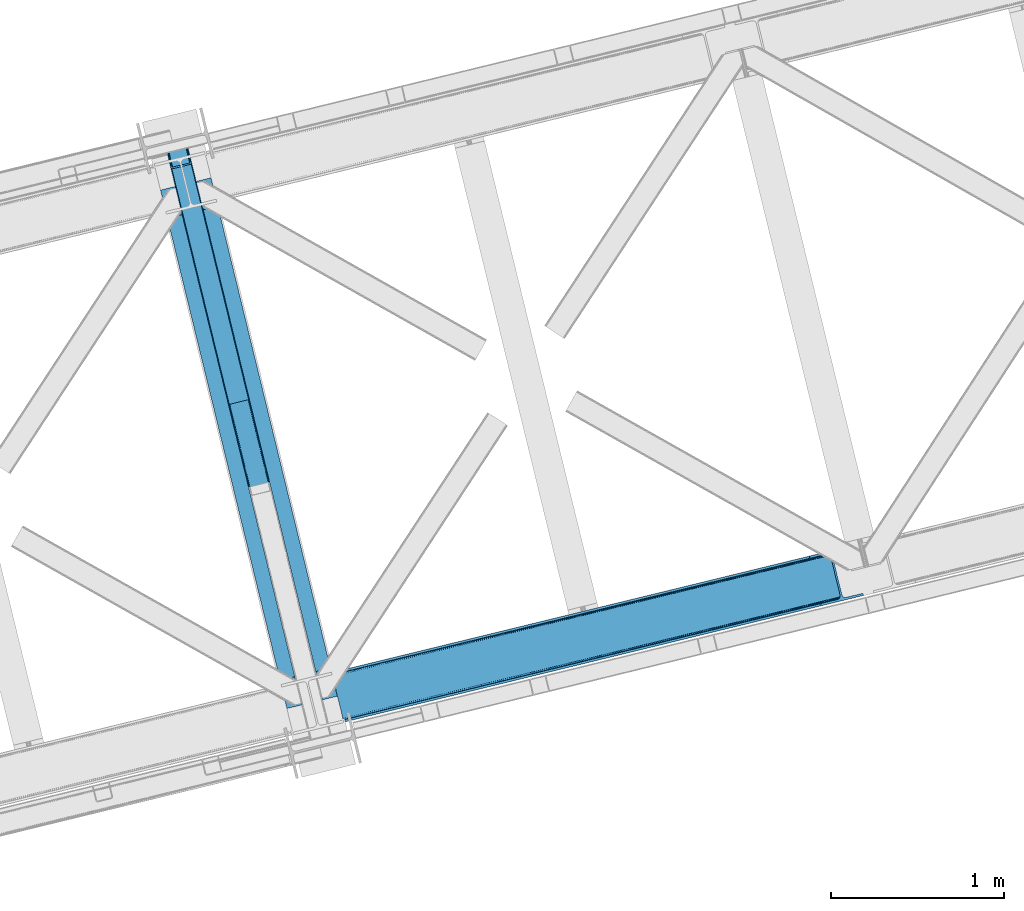
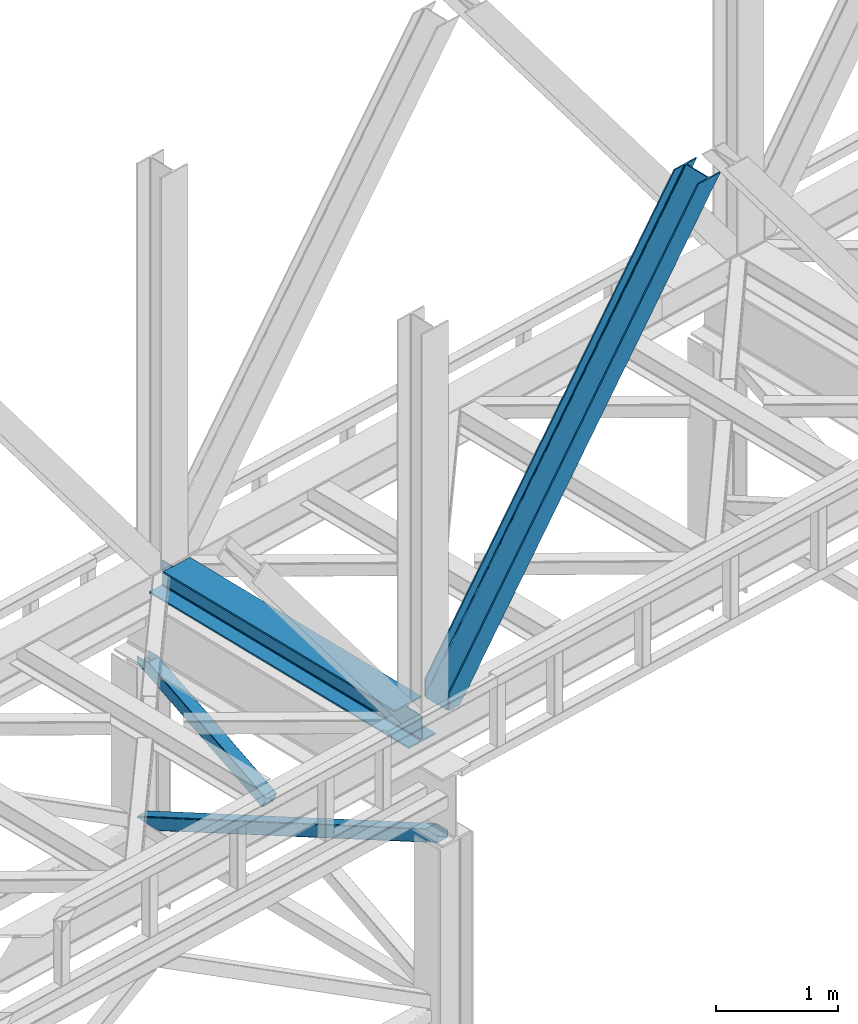
# One storey, part 52 of 92: 3 members, 1 beam.
"""IFC4 building model written with IfcOpenShell, lengths in millimetres."""

from ifc_helpers import new_model, entity, si_unit, converted_unit, derived_unit, direction, frame, origin, place, context, subcontext, project, spatial, triangles, polygons, material, type_object, element, save


model = new_model("IFC4")

# Units and contexts
model_context = context("Model", 3, precision=0.01, world=origin(), true_north=direction((6.12303176911189e-17, 1.0)))
plan_context = context("Plan", 3, precision=0.01, world=origin(), true_north=direction((6.12303176911189e-17, 1.0)))
body_context = subcontext(model_context, "Body", "Model", "MODEL_VIEW")
ifc_project = project(units=[si_unit("LENGTHUNIT", "METRE", prefix="MILLI"), si_unit("AREAUNIT", "SQUARE_METRE"), si_unit("VOLUMEUNIT", "CUBIC_METRE"), converted_unit("PLANEANGLEUNIT", "DEGREE", entity("IfcRatioMeasure", 0.0174532925199433), si_unit("PLANEANGLEUNIT", "RADIAN"), dimensions=[0, 0, 0, 0, 0, 0, 0]), si_unit("MASSUNIT", "GRAM", prefix="KILO"), derived_unit("MASSDENSITYUNIT", [(si_unit("MASSUNIT", "GRAM", prefix="KILO"), 1), (si_unit("LENGTHUNIT", "METRE"), -3)]), derived_unit("MOMENTOFINERTIAUNIT", [(si_unit("LENGTHUNIT", "METRE"), 4)]), si_unit("TIMEUNIT", "SECOND"), si_unit("FREQUENCYUNIT", "HERTZ"), si_unit("THERMODYNAMICTEMPERATUREUNIT", "DEGREE_CELSIUS"), derived_unit("THERMALTRANSMITTANCEUNIT", [(si_unit("MASSUNIT", "GRAM", prefix="KILO"), 1), (si_unit("THERMODYNAMICTEMPERATUREUNIT", "KELVIN"), -1), (si_unit("TIMEUNIT", "SECOND"), -3)]), derived_unit("VOLUMETRICFLOWRATEUNIT", [(si_unit("LENGTHUNIT", "METRE"), 3), (si_unit("TIMEUNIT", "SECOND"), -1)]), derived_unit("MASSFLOWRATEUNIT", [(si_unit("MASSUNIT", "GRAM", prefix="KILO"), 1), (si_unit("TIMEUNIT", "SECOND"), -1)]), derived_unit("ROTATIONALFREQUENCYUNIT", [(si_unit("TIMEUNIT", "SECOND"), -1)]), si_unit("ELECTRICCURRENTUNIT", "AMPERE"), si_unit("ELECTRICVOLTAGEUNIT", "VOLT"), si_unit("POWERUNIT", "WATT"), si_unit("FORCEUNIT", "NEWTON", prefix="KILO"), si_unit("ILLUMINANCEUNIT", "LUX"), si_unit("LUMINOUSFLUXUNIT", "LUMEN"), si_unit("LUMINOUSINTENSITYUNIT", "CANDELA"), derived_unit("USERDEFINED", [(si_unit("MASSUNIT", "GRAM", prefix="KILO"), -1), (si_unit("LENGTHUNIT", "METRE"), -2), (si_unit("TIMEUNIT", "SECOND"), 3), (si_unit("LUMINOUSFLUXUNIT", "LUMEN"), 1)]), derived_unit("LINEARVELOCITYUNIT", [(si_unit("LENGTHUNIT", "METRE"), 1), (si_unit("TIMEUNIT", "SECOND"), -1)]), si_unit("PRESSUREUNIT", "PASCAL"), derived_unit("USERDEFINED", [(si_unit("LENGTHUNIT", "METRE"), -2), (si_unit("MASSUNIT", "GRAM", prefix="KILO"), 1), (si_unit("TIMEUNIT", "SECOND"), -2)]), derived_unit("LINEARFORCEUNIT", [(si_unit("MASSUNIT", "GRAM", prefix="KILO"), 1), (si_unit("LENGTHUNIT", "METRE"), 1), (si_unit("TIMEUNIT", "SECOND"), -2), (si_unit("LENGTHUNIT", "METRE"), -1)]), derived_unit("PLANARFORCEUNIT", [(si_unit("MASSUNIT", "GRAM", prefix="KILO"), 1), (si_unit("LENGTHUNIT", "METRE"), 1), (si_unit("TIMEUNIT", "SECOND"), -2), (si_unit("LENGTHUNIT", "METRE"), -2)])], contexts=[model_context, plan_context])

# Site, building, storey
site_placement = place(None, origin())
site = spatial("IfcSite", under=ifc_project, at=site_placement, CompositionType="ELEMENT")
building_placement = place(site_placement, origin())
building = spatial("IfcBuilding", under=site, at=building_placement, CompositionType="ELEMENT")
storey_placement = place(building_placement, frame((0.0, 0.0, 15900.0)))
storey = spatial("IfcBuildingStorey", under=building, at=storey_placement, Name="05", CompositionType="ELEMENT", Elevation=15900.0)

# Beam
ifc_material = material(Name="Metal painted (White)")
beam_type = type_object("IfcBeamType", PredefinedType="BEAM")
beam_placement = place(storey_placement, frame((-36670.83, 8847.8, 3385.0)))
element("IfcBeam", 1, at=beam_placement, inside=storey, type_object=beam_type, material=ifc_material, ObjectType="Steel Beam", PredefinedType="BEAM", context=body_context, shape_type="Tessellation", body=[
    polygons([(1022.42935345712, 71.0478278971032, 15.4999999999986), (1022.42935345712, 71.047827897101, 0.0), (291.465617442442, 3069.74325535076, 0.0), (291.465617442442, 3069.74325535076, 15.4999999999986), (899.042242073157, 40.970914087328, 15.4999999999986), (168.078506058478, 3039.66634154099, 15.4999999999986), (892.349898299203, 39.3395844888254, 16.8701684147963), (161.386162284524, 3038.03501194248, 16.8701684147963), (886.676403198579, 37.9566100336519, 20.7720779386413), (155.7126671839, 3036.65203748731, 20.7720779386413), (882.88549497, 37.0325360459162, 26.6116982174294), (151.921758955325, 3035.72796349958, 26.6116982174294), (881.554305026607, 36.7080444135029, 33.500000000001), (150.590569011932, 3035.40347186716, 33.500000000001), (140.875048430518, 3033.03521093726, 33.500000000001), (140.875048430518, 3033.03521093726, 259.000000000002), (150.590569011932, 3035.40347186716, 259.000000000002), (4.33146851719357e-12, 2998.69542745366, 0.0), (4.33146851719357e-12, 2998.69542745366, 15.4999999999986), (123.387111383964, 3028.77234126343, 15.4999999999986), (130.079455157922, 3030.40367086194, 16.8701684147963), (135.752950258542, 3031.78664531711, 20.7720779386413), (139.543858487117, 3032.71071930484, 26.6116982174294), (881.554305026612, 36.7080444135018, 259.000000000002), (871.838784445197, 34.3397834835992, 259.000000000002), (871.838784445197, 34.3397834835981, 33.500000000001), (870.507594501796, 34.0152918511827, 26.6116982174294), (866.716686273221, 33.0912178634492, 20.7720779386413), (861.043191172601, 31.7082434082767, 16.8701684147963), (854.350847398639, 30.0769138097708, 15.4999999999986), (730.963736014684, 1.08286712929839e-12, 15.4999999999986), (730.963736014675, 1.08286712929839e-12, 0.0), (841.854534586248, 199.571930111232, 259.069791776412), (190.199733064572, 2872.911390143, 259.000000000002), (190.423126166417, 2871.99494573803, 259.61730333112), (190.435515010051, 2871.94412150426, 266.500003008253), (841.709355772749, 200.167408132524, 266.500002998871), (841.709705893497, 200.16597182779, 260.000004007589), (832.229597305449, 196.831858094286, 259.006343172366), (832.006227290708, 197.748309612731, 259.61730333112), (831.993838447078, 197.799133846506, 266.500003008253), (180.719997684385, 2869.57584721824, 266.500002998871), (180.719647563629, 2869.57728352297, 260.000004007589), (180.574841905293, 2870.17133233676, 259.07612046749), (180.484212483149, 2870.5431292131, 259.000000000002), (843.040843642663, 200.490677577209, 273.388305639783), (846.831120231363, 201.417342749122, 279.227924098781), (852.504191178897, 202.8020572128, 283.129832400619), (859.196382860031, 204.434010743613, 284.500000377228), (982.583411547866, 234.511263798723, 284.500000138971), (982.581741741215, 234.518113867454, 299.999995328161), (691.116319643944, 163.469484603412, 299.999995890962), (691.117989450605, 163.462634534681, 284.500000701776), (814.50501813844, 193.539887589791, 284.500000463519), (821.197505034579, 195.170630056369, 283.129832461069), (826.871416683348, 196.551895700895, 279.227924137322), (830.662951470335, 197.473399350192, 273.388305663684), (179.388509814454, 2869.25257777355, 273.388305639783), (175.598233225758, 2868.32591260164, 279.227924098781), (169.925162278228, 2866.94119813796, 283.129832400619), (163.232970597094, 2865.30924460715, 284.500000377228), (39.8459419092591, 2835.23199155204, 284.500000138971), (39.8476117159108, 2835.22514148331, 299.999995328161), (331.313033813177, 2906.27377074735, 299.999995890962), (331.311364006521, 2906.28062081608, 284.500000701776), (207.924335318677, 2876.20336776097, 284.500000463519), (201.231848422542, 2874.57262529439, 283.129832461069), (195.557936773782, 2873.19135964986, 279.227924137322), (191.766401986782, 2872.26985600057, 273.388305663684)], [[[1, 2, 3, 4]], [[5, 1, 4, 6]], [[7, 5, 6, 8]], [[9, 7, 8, 10]], [[11, 9, 10, 12]], [[13, 11, 12, 14]], [[15, 16, 17, 14, 12, 10, 8, 6, 4, 3, 18, 19, 20, 21, 22, 23]], [[13, 24, 25, 26, 27, 28, 29, 30, 31, 32, 2, 1, 5, 7, 9, 11]], [[2, 32, 18, 3]], [[32, 31, 19, 18]], [[31, 30, 20, 19]], [[27, 26, 15, 23]], [[28, 27, 23, 22]], [[29, 28, 22, 21]], [[30, 29, 21, 20]], [[33, 24, 13, 14, 17, 34, 35, 36, 37, 38]], [[25, 39, 40, 41, 42, 43, 44, 16, 15, 26]], [[39, 25, 24, 33]], [[45, 34, 17, 16]], [[41, 40, 38, 37, 46, 47, 48, 49, 50, 51, 52, 53, 54, 55, 56, 57]], [[42, 58, 59, 60, 61, 62, 63, 64, 65, 66, 67, 68, 69, 36, 35, 43]], [[46, 37, 36, 69]], [[47, 46, 69, 68]], [[48, 47, 68, 67]], [[49, 48, 67, 66]], [[50, 49, 66, 65]], [[51, 50, 65, 64]], [[52, 51, 64, 63]], [[53, 52, 63, 62]], [[54, 53, 62, 61]], [[55, 54, 61, 60]], [[56, 55, 60, 59]], [[57, 56, 59, 58]], [[41, 57, 58, 42]]], closed=False),
])

# Members
member_type_1 = type_object("IfcMemberType", PredefinedType="BRACE")
member_1_placement = place(storey_placement, frame((-35677.02, 8771.36, 3695.0)))
element("IfcMember", 2, at=member_1_placement, inside=storey, type_object=member_type_1, ObjectType="Steel Vertical Brace", PredefinedType="BRACE", context=body_context, shape_type="Tessellation", body=[
    triangles([(58.5289855957017, 27.9221328735348, 0.0), (60.4567749023481, 20.0173828124989, 0.0), (59.0987182617173, 20.9713943481438, 0.827856445310317), (58.9708190917954, 19.7935592651356, 1.13481445312209), (72.0374633789106, 11.6585906982418, 0.0), (71.2235595703169, 13.9003143310547, 30.2981506347642), (70.081768798831, 15.4002227783203, 25.0194030761704), (72.0374633789106, 11.6585906982418, 170.803527832031), (71.7537597656265, 12.6189971923832, 41.9881347656228), (71.7537597656265, 12.6189971923832, 170.743066406249), (70.2445495605498, 15.5234710693348, 0.0), (68.6446472167954, 17.2873168945316, 18.377947998044), (66.9517272949233, 18.0907562255852, 14.9735046386704), (67.1191589355512, 18.4180618286136, 0.0), (63.1287048339873, 19.9086685180664, 7.26932373046657), (63.1287048339873, 19.9086685180664, 0.0), (2824.67409667969, 683.67222290039, 3911.00081176758), (2919.44040527344, 706.773138427734, 3911.00081176758), (2937.07886352539, 722.50938720703, 3911.00081176758), (2933.70465087891, 715.676664733886, 3911.00081176758), (2937.11839599609, 729.608953857422, 3911.00081176758), (2927.51200561524, 710.150839233398, 3911.00081176758), (2827.75297851563, 671.042179870605, 3911.00081176758), (74.879150390625, 0.0, 170.803527832031), (74.879150390625, 0.0, 0.0), (192.937060546879, 28.7778945922855, 0.0), (3071.52647094727, 730.464715576172, 3911.00081176758), (3068.44758911133, 743.094758605957, 3911.00081176758), (189.858178710936, 41.4085189819325, 0.0), (2973.67895507813, 719.994424438477, 3911.00081176758), (95.0918701171904, 18.308184814452, 0.0), (2964.96088256836, 719.278770446777, 3911.00081176758), (86.3714721679717, 17.5925308227543, 0.0), (2956.91951293945, 721.335040283202, 3911.00081176758), (78.330102539061, 19.6482192993153, 0.0), (2950.77802734375, 725.848718261719, 3911.00081176758), (72.190942382811, 24.1624786376942, 0.0), (2947.47822875977, 732.134381103515, 3911.00081176758), (68.8888183593735, 30.4481414794918, 0.0), (2892.29787597656, 958.506028747559, 3911.00081176758), (13.7084655761719, 256.819789123534, 0.0), (2892.33508300781, 965.605014038085, 3911.00081176758), (13.7479980468779, 263.918774414062, 0.0), (2895.7092956543, 972.438317871094, 3911.00081176758), (17.1198852539092, 270.751496887207, 0.0), (2901.90194091797, 977.964143371582, 3911.00081176758), (23.3125305175781, 276.277322387696, 0.0), (2909.97354125977, 981.341844177246, 3911.00081176758), (31.386456298831, 279.655604553222, 0.0), (3004.74217529297, 1004.44275970459, 3911.00081176758), (126.152764892577, 302.755938720702, 0.0), (3001.66329345703, 1017.07222137451, 3911.00081176758), (123.073883056641, 315.385981750487, 0.0), (2881.93804321289, 955.980601501464, 3911.00081176758), (3.3486328125, 254.293780517577, 0.0), (2872.4967590332, 966.779942321777, 3911.00081176758), (2864.4553894043, 968.835630798339, 3911.00081176758), (2757.88747558594, 957.650267028808, 3911.00081176758), (2855.73499145508, 968.120558166504, 3911.00081176758), (2760.96635742188, 945.019642639159, 3911.00081176758), (2878.63359375, 962.265682983398, 3911.00081176758), (5.01364746093896, 286.608087158203, 170.803527832031), (5.01364746093896, 286.608087158203, 0.0), (7.85533447266062, 274.94949645996, 170.803527832031), (8.04834594726708, 273.966416931153, 170.743066406249), (8.04834594726708, 273.966416931153, 41.9881347656228), (7.85533447266062, 274.94949645996, 0.0), (3.74628295898583, 263.525775146483, 0.0), (6.60192260742042, 266.684884643555, 0.0), (8.04369506835792, 270.693360900879, 0.0), (1.42084350586083, 262.199111938477, 0.0), (3.74628295898583, 263.525775146483, 7.26932373046657), (6.30194091796875, 266.898825073242, 14.9735046386704), (7.43442993164354, 268.390594482422, 18.377947998044), (8.16694335937791, 272.585105895996, 30.2981506347642), (7.84138183594041, 270.727079772949, 25.0194030761704), (0.0, 261.714839172362, 1.13481445312209), (0.65577392578416, 260.727690124511, 0.827856445310317)], [[1, 2, 3], [4, 3, 2], [5, 6, 7], [5, 8, 9], [10, 9, 8], [9, 6, 5], [11, 12, 13], [11, 7, 12], [14, 13, 15], [15, 4, 2], [2, 16, 15], [15, 16, 14], [13, 14, 11], [7, 11, 5], [17, 18, 10], [9, 10, 18], [19, 3, 15], [15, 20, 19], [12, 20, 13], [15, 13, 20], [3, 4, 15], [19, 21, 1], [1, 3, 19], [6, 20, 7], [6, 22, 20], [12, 7, 20], [18, 22, 9], [6, 9, 22], [8, 17, 10], [23, 8, 24], [8, 23, 17], [25, 24, 5], [8, 5, 24], [23, 26, 27], [26, 23, 24], [25, 26, 24], [28, 27, 29], [26, 29, 27], [30, 28, 29], [29, 31, 30], [32, 30, 31], [31, 33, 32], [34, 32, 33], [33, 35, 34], [36, 34, 35], [35, 37, 36], [38, 36, 37], [37, 39, 38], [40, 38, 41], [39, 41, 38], [42, 40, 43], [41, 43, 40], [44, 42, 45], [43, 45, 42], [46, 44, 47], [45, 47, 44], [48, 46, 49], [47, 49, 46], [50, 48, 51], [49, 51, 48], [52, 50, 51], [51, 53, 52], [21, 54, 1], [55, 1, 54], [54, 21, 38], [20, 22, 32], [18, 23, 27], [17, 23, 18], [22, 18, 30], [21, 19, 36], [19, 20, 34], [56, 46, 57], [58, 59, 52], [59, 57, 48], [58, 60, 59], [56, 61, 44], [61, 54, 42], [40, 54, 38], [30, 32, 22], [36, 19, 34], [32, 34, 20], [36, 38, 21], [27, 30, 18], [27, 28, 30], [48, 57, 46], [44, 61, 42], [40, 42, 54], [44, 46, 56], [48, 52, 59], [52, 48, 50], [58, 53, 62], [58, 52, 53], [53, 63, 62], [64, 58, 62], [60, 64, 65], [64, 60, 58], [59, 60, 65], [65, 66, 59], [67, 64, 62], [62, 63, 67], [11, 35, 5], [68, 41, 55], [69, 70, 43], [69, 43, 68], [55, 71, 68], [67, 63, 47], [67, 45, 70], [55, 39, 1], [37, 14, 16], [2, 1, 16], [16, 1, 39], [11, 14, 37], [25, 5, 33], [39, 55, 41], [49, 47, 63], [43, 70, 45], [47, 45, 67], [43, 41, 68], [53, 49, 63], [53, 51, 49], [31, 25, 33], [35, 11, 37], [39, 37, 16], [35, 33, 5], [31, 26, 25], [26, 31, 29], [72, 68, 71], [69, 68, 72], [70, 69, 73], [73, 74, 70], [67, 75, 66], [67, 70, 76], [76, 75, 67], [64, 67, 66], [66, 65, 64], [74, 76, 70], [72, 73, 69], [71, 77, 72], [78, 61, 72], [61, 56, 74], [74, 73, 61], [73, 72, 61], [57, 59, 66], [66, 75, 57], [56, 75, 76], [75, 56, 57], [76, 74, 56], [72, 77, 78], [54, 61, 55], [78, 55, 61], [71, 55, 78], [78, 77, 71]]),
])
member_type_2 = type_object("IfcMemberType", PredefinedType="BRACE")
member_2_placement = place(storey_placement, frame((-36642.89, 10607.33, 1820.91)))
element("IfcMember", 3, at=member_2_placement, inside=storey, type_object=member_type_2, ObjectType="Steel Vertical Brace", PredefinedType="BRACE", context=body_context, shape_type="Tessellation", body=[
    polygons([(29.8135191782847, 1388.61826467864, 771.091297096984), (32.1113287327985, 1381.7631169139, 771.091297096989), (368.111452939622, 3.36089743274203, 105.060837153748), (367.211709770163, 4.48063717440627, 102.289544138114), (35.2425975620341, 1376.24004026086, 771.091297096982), (370.057498317433, 2.70006492288447, 107.410225929579), (38.7306183717297, 1372.88987307312, 771.091297096989), (372.75357813572, 2.59874540396945, 108.980037321763), (42.0443716126254, 1372.22264793569, 771.091297096984), (375.789238682203, 3.07236385431241, 109.531281776207), (140.171129484908, 1396.14208332771, 771.091297096984), (473.915996554486, 26.9917992463345, 109.531281776209), (142.806126265313, 1398.25937921937, 771.091297096991), (476.829086029299, 27.9682515502176, 108.980037321767), (144.361212211713, 1402.83885703392, 771.091297096984), (479.176112967108, 29.2988816959484, 107.410225929583), (144.599639585688, 1409.18333278718, 771.091297096997), (480.599763792516, 30.7811133060222, 105.060837153757), (143.485109980843, 1416.32691755851, 771.091297096984), (480.883300572716, 32.1892900542756, 102.289544138114), (149.600536198011, 1408.12910918704, 771.09129709698), (121.44400726769, 1523.63806044727, 771.091297096982), (117.557799035115, 1522.69075607531, 771.09129709698), (3.88620823256572, 1494.98210319544, 771.091297096982), (4.33146851719357e-12, 1494.03479882348, 771.091297096982), (28.1565289303171, 1378.52584756325, 771.09129709698), (30.4543384848309, 1371.67069979849, 771.091297096982), (33.5856073140622, 1366.14762314544, 771.091297096982), (37.0736281237621, 1362.79745595771, 771.091297096984), (40.3873813646535, 1362.13023082029, 771.09129709698), (146.286555702072, 1387.94427495624, 771.09129709698), (148.921552482481, 1390.06157084789, 771.091297096984), (150.476638428881, 1394.64104866244, 771.09129709698), (150.715065802839, 1400.98552441569, 771.09129709698), (359.725704690142, 52.0811507006333, 4.33146851719357e-12), (465.62487902756, 77.8951948365801, 2.16573425859679e-12), (468.660539574047, 78.3688132869209, 0.551244454446396), (471.356619392343, 78.2674937680102, 2.12105584662818), (473.302664770137, 77.6066612581418, 4.4704446224671), (474.202407939605, 76.4869215164841, 7.24173763810153), (485.172065028735, 31.4851533942308, 105.910412957166), (484.888528248512, 30.0769766459796, 108.681705972796), (483.46487742313, 28.5947450359037, 111.031094748631), (481.117850485317, 27.2641148901728, 112.600906140819), (478.204761010504, 26.2876625862876, 113.152150595261), (372.305586673086, 0.473618450342957, 113.152150595257), (369.269926126603, 2.16573425859679e-12, 112.600906140819), (366.573846308307, 0.101319518910685, 111.031094748635), (364.627800930509, 0.76215202877691, 108.681705972796), (363.728057761045, 1.88189177043682, 105.910412957166), (352.758400671911, 46.8836598926901, 7.24173763810153), (353.041937452142, 48.2918366409434, 4.4704446224671), (354.465588277524, 49.7740682510194, 2.12105584662385), (356.812615215332, 51.1046983967459, 0.551244454448562), (470.718755930487, 73.8881761125124, 10.8626064571491), (469.819012761023, 75.0079158541724, 8.09131344151462), (467.872967383238, 75.6687483640429, 5.74192466567137), (465.176887564938, 75.7700678829471, 4.17211327349608), (462.141227018446, 75.2964494326085, 3.62086881905185), (364.01446914616, 51.3770140405842, 3.62086881905185), (361.101379671355, 50.4005617366968, 4.17211327349392), (358.754352733542, 49.0699315909703, 5.74192466567787), (357.33070190816, 47.5876999808965, 8.09131344151462), (357.047165127938, 46.1795232326431, 10.8626064571491), (3.88620823256572, 1494.98210319544, 710.909831470177), (117.557799035128, 1522.69075607531, 710.909831470175), (11.6586246977015, 1496.87671193936, 702.072173549059), (8.91066050334255, 1496.2068665941, 703.366418586696), (6.16269630900526, 1495.53702124884, 704.660663624354), (5.02445227078982, 1495.25956222214, 707.785247547264), (116.4195549969, 1522.41329704861, 707.785247547264), (115.281310958689, 1522.13583802191, 704.660663624352), (112.533346764343, 1521.46599267665, 703.3664185867), (109.785382569988, 1520.79614733139, 702.072173549057), (120.30576322947, 1523.36060142057, 703.366418586702), (119.167519191254, 1523.08314239387, 700.241834663787), (116.419554996904, 1522.41329704861, 698.94758962614), (113.671590802554, 1521.74345170335, 697.653344588497), (7.77241646513577, 1495.9294075674, 697.653344588497), (5.02445227078549, 1495.25956222214, 698.947589626138), (2.27648807643955, 1494.58971687688, 700.241834663785), (1.13824403821544, 1494.31225785018, 703.366418586702), (4.33146851719357e-12, 1494.03479882348, 706.491002509615), (121.44400726769, 1523.63806044727, 706.491002509615)], [[[1, 2, 3, 4]], [[2, 5, 6, 3]], [[5, 7, 8, 6]], [[7, 9, 10, 8]], [[9, 11, 12, 10]], [[11, 13, 14, 12]], [[13, 15, 16, 14]], [[15, 17, 18, 16]], [[17, 19, 20, 18]], [[21, 22, 23, 19, 17, 15, 13, 11, 9, 7, 5, 2, 1, 24, 25, 26, 27, 28, 29, 30, 31, 32, 33, 34]], [[35, 36, 37, 38, 39, 40, 41, 42, 43, 44, 45, 46, 47, 48, 49, 50, 51, 52, 53, 54], [55, 56, 57, 58, 59, 60, 61, 62, 63, 64, 4, 3, 6, 8, 10, 12, 14, 16, 18, 20]], [[24, 1, 4, 64, 65]], [[19, 23, 66, 55, 20]], [[61, 67, 68]], [[62, 68, 69]], [[63, 69, 70]], [[64, 70, 65]], [[70, 64, 63]], [[69, 63, 62]], [[68, 62, 61]], [[67, 61, 60]], [[55, 71, 56]], [[56, 72, 57]], [[57, 73, 58]], [[58, 74, 59]], [[74, 58, 73]], [[73, 57, 72]], [[72, 56, 71]], [[71, 55, 66]], [[74, 67, 60, 59]], [[75, 76, 77, 78, 79, 80, 81, 82, 83, 25, 24, 65, 70, 69, 68, 67, 74, 73, 72, 71, 66, 23, 22, 84]], [[30, 29, 47, 46]], [[29, 28, 48, 47]], [[28, 27, 49, 48]], [[27, 26, 50, 49]], [[45, 31, 30, 46]], [[21, 34, 42, 41]], [[34, 33, 43, 42]], [[33, 32, 44, 43]], [[32, 31, 45, 44]], [[50, 26, 25, 83, 51]], [[84, 22, 21, 41, 40]], [[51, 82, 52]], [[52, 81, 53]], [[53, 80, 54]], [[54, 79, 35]], [[79, 54, 80]], [[80, 53, 81]], [[81, 52, 82]], [[82, 51, 83]], [[37, 78, 77]], [[38, 77, 76]], [[39, 76, 75]], [[40, 75, 84]], [[75, 40, 39]], [[76, 39, 38]], [[77, 38, 37]], [[78, 37, 36]], [[35, 79, 78, 36]]], closed=True),
])
member_type_3 = type_object("IfcMemberType", PredefinedType="BRACE")
member_3_placement = place(storey_placement, frame((-36642.89, 8634.38, 970.5)))
element("IfcMember", 4, at=member_3_placement, inside=storey, type_object=member_type_3, ObjectType="Steel Vertical Brace", PredefinedType="BRACE", context=body_context, shape_type="Tessellation", body=[
    triangles([(177.817053222658, 3231.5446105957, 0.0), (958.785662841794, 27.7087738037098, 1548.06132202148), (852.885150146481, 1.89465179443323, 1548.06132202148), (71.9165405273452, 3205.72990722656, 0.0), (961.532006835936, 28.3785003662106, 1549.35542907715), (964.280676269533, 29.0482269287113, 1550.65069885254), (180.451776123045, 3233.66192321777, 0.0), (965.420141601564, 29.3255355834954, 1553.77492675781), (182.00516967773, 3238.24071350098, 0.0), (966.557281494141, 29.6034255981449, 1556.89915466309), (182.244689941406, 3244.58567504883, 0.0), (181.130804443361, 3251.72942504883, 0.0), (845.113531494142, 0.0, 1556.89915466309), (59.687054443355, 3222.12658081055, 0.0), (61.9845886230469, 3215.27118530273, 0.0), (846.252996826173, 0.27789001464771, 1553.77492675781), (65.1146301269546, 3209.74710388183, 0.0), (847.39013671875, 0.554617309569949, 1550.65069885254), (68.6027893066421, 3206.39730834961, 0.0), (850.138806152339, 1.2249252319325, 1549.35542907715), (121.443749999999, 3496.58657226563, 2.0998718261726), (938.400860595699, 145.112072753906, 1621.4998626709), (121.443749999999, 3496.58657226563, 0.0), (966.557281494141, 29.6034255981449, 1621.4998626709), (0.0, 3466.98372802734, 2.0998718261726), (816.9571105957, 115.509228515624, 1621.4998626709), (0.0, 3466.98372802734, 0.0), (845.113531494142, 0.0, 1621.4998626709), (116.418475341794, 3495.36222839355, 9.64359741210865), (113.672131347652, 3494.69250183105, 10.9377044677749), (926.171374511716, 161.507583618164, 1621.4998626709), (119.167144775391, 3496.03195495605, 8.34949035644604), (929.482800292964, 160.840182495116, 1621.4998626709), (120.304284667967, 3496.30868225098, 5.22409973144386), (932.970959472652, 157.490386962891, 1621.4998626709), (936.103326416014, 151.967468261719, 1621.4998626709), (7.77161865233938, 3468.87779846191, 10.9377044677749), (820.270861816403, 135.693461608886, 1621.4998626709), (815.843225097655, 122.652397155762, 1621.4998626709), (1.13946533203125, 3467.26161804199, 5.22409973144386), (816.080419921876, 128.996777343749, 1621.4998626709), (2.27660522460792, 3467.53834533691, 8.34949035644604), (817.636138916016, 133.576148986816, 1621.4998626709), (5.02527465820458, 3468.20807189941, 9.64359741210865), (4.15788574218459, 3467.99645690918, 0.0), (4.76482543945167, 3468.14528503418, 0.782510375975107), (6.74609985351708, 3468.6278137207, 3.34281921386719), (117.283538818359, 3495.57268066406, 0.0), (116.799847412105, 3495.45408325195, 0.95459289550854), (115.281335449217, 3495.08433837891, 3.92999267578125), (8.68551635742188, 3469.10104064941, 5.84615478515479), (109.786322021486, 3493.74488525391, 6.51936950683739), (11.6574279785127, 3469.82541503906, 6.51936950683739), (112.532666015621, 3494.41461181641, 5.22409973144386), (924.513336181641, 151.415757751465, 1621.4998626709), (826.386767578122, 127.495706176758, 1621.4998626709), (118.727636718751, 3490.84157409668, 0.0), (936.745147705078, 135.019665527343, 1621.4998626709), (934.445288085939, 141.875061035156, 1621.4998626709), (931.315246582031, 147.397979736328, 1621.4998626709), (927.827087402344, 150.747775268554, 1621.4998626709), (962.671472167967, 28.6558090209965, 1621.4998626709), (822.196325683595, 120.79902191162, 1621.4998626709), (823.752044677734, 125.378974914551, 1621.4998626709), (823.073016357419, 107.310891723633, 1621.4998626709), (821.959130859374, 114.454641723632, 1621.4998626709), (848.999340820308, 0.947616577148438, 1621.4998626709), (5.05550537109229, 3463.13280029297, 0.0), (175.014898681642, 3259.92659912109, 0.0), (962.671472167967, 28.6558090209965, 1561.31865234375), (61.3427673339829, 3232.21782531738, 0.0), (848.999340820308, 0.947616577148438, 1561.31865234375), (66.7703430175752, 3219.8395111084, 0.0), (63.6426269531221, 3225.3635925293, 0.0), (70.2608276367173, 3216.48971557617, 0.0), (73.5745788574204, 3215.82231445312, 0.0), (175.889263916011, 3246.43905029297, 0.0), (176.128784179688, 3252.78284912109, 0.0), (174.335870361327, 3241.85909729004, 0.0), (171.701147460939, 3239.74178466797, 0.0), (954.899853515621, 26.7617385864251, 1552.48081970215), (957.646197509763, 27.4308837890621, 1553.77492675781), (960.394866943359, 28.1006103515629, 1555.06903381348), (856.773284912109, 2.84168701171802, 1552.48081970215), (854.024615478513, 2.17196044921911, 1553.77492675781), (851.275946044923, 1.50165252685474, 1555.06903381348), (961.532006835936, 28.3785003662106, 1558.19326171875), (850.138806152339, 1.2249252319325, 1558.19326171875)], [[1, 2, 3], [3, 4, 1], [5, 2, 1], [6, 5, 7], [8, 6, 9], [10, 8, 11], [11, 12, 10], [9, 11, 8], [7, 9, 6], [1, 7, 5], [13, 14, 15], [16, 15, 17], [18, 17, 19], [20, 19, 4], [4, 3, 20], [19, 20, 18], [17, 18, 16], [15, 16, 13], [12, 21, 22], [12, 23, 21], [22, 10, 12], [24, 10, 22], [25, 14, 26], [14, 25, 27], [13, 26, 14], [28, 26, 13], [29, 30, 31], [32, 29, 33], [34, 32, 35], [21, 34, 36], [36, 22, 21], [35, 36, 34], [33, 35, 32], [31, 33, 29], [31, 30, 37], [37, 38, 31], [25, 26, 39], [40, 39, 41], [42, 41, 43], [44, 43, 38], [38, 37, 44], [43, 44, 42], [41, 42, 40], [39, 40, 25], [45, 25, 46], [45, 27, 25], [46, 40, 47], [40, 42, 47], [25, 40, 46], [48, 21, 23], [21, 48, 49], [49, 34, 21], [34, 49, 50], [47, 44, 51], [37, 30, 52], [53, 51, 37], [52, 53, 37], [51, 44, 37], [42, 44, 47], [30, 54, 52], [29, 50, 54], [50, 32, 34], [50, 29, 32], [30, 29, 54], [52, 55, 56], [56, 53, 52], [57, 58, 59], [49, 48, 57], [49, 59, 60], [50, 60, 61], [54, 61, 55], [55, 52, 54], [61, 54, 50], [60, 50, 49], [59, 49, 57], [61, 60, 36], [35, 61, 36], [61, 35, 33], [55, 31, 38], [33, 55, 61], [31, 55, 33], [60, 22, 36], [24, 58, 62], [24, 22, 58], [60, 59, 22], [59, 58, 22], [39, 63, 64], [38, 56, 55], [56, 43, 64], [43, 56, 38], [64, 41, 39], [41, 64, 43], [26, 63, 39], [65, 66, 26], [66, 63, 26], [65, 28, 67], [26, 28, 65], [47, 51, 64], [46, 47, 63], [68, 46, 66], [66, 65, 68], [68, 45, 46], [63, 66, 46], [64, 63, 47], [53, 56, 51], [64, 51, 56], [58, 69, 70], [58, 57, 69], [70, 62, 58], [71, 65, 72], [65, 71, 68], [67, 72, 65], [73, 15, 14], [27, 68, 71], [68, 27, 45], [14, 71, 74], [71, 14, 27], [74, 73, 14], [75, 15, 73], [17, 75, 19], [17, 15, 75], [19, 76, 4], [4, 76, 1], [75, 76, 19], [12, 11, 77], [78, 69, 12], [77, 78, 12], [23, 57, 48], [69, 23, 12], [57, 23, 69], [11, 79, 77], [80, 7, 1], [80, 1, 76], [80, 79, 7], [79, 9, 7], [79, 11, 9], [81, 3, 2], [2, 5, 82], [6, 83, 5], [83, 82, 5], [2, 82, 81], [83, 6, 8], [84, 3, 81], [20, 85, 86], [20, 3, 85], [86, 18, 20], [18, 86, 16], [84, 85, 3], [87, 10, 70], [8, 87, 83], [10, 87, 8], [24, 70, 10], [24, 62, 70], [16, 88, 13], [13, 88, 72], [86, 88, 16], [72, 28, 13], [28, 72, 67], [81, 80, 76], [76, 84, 81], [70, 69, 78], [87, 78, 77], [83, 77, 79], [82, 79, 80], [80, 81, 82], [79, 82, 83], [77, 83, 87], [78, 87, 70], [85, 84, 76], [86, 85, 75], [88, 86, 73], [72, 88, 74], [74, 71, 72], [73, 74, 88], [75, 73, 86], [76, 75, 85]]),
])

save(model, "model.ifc")
